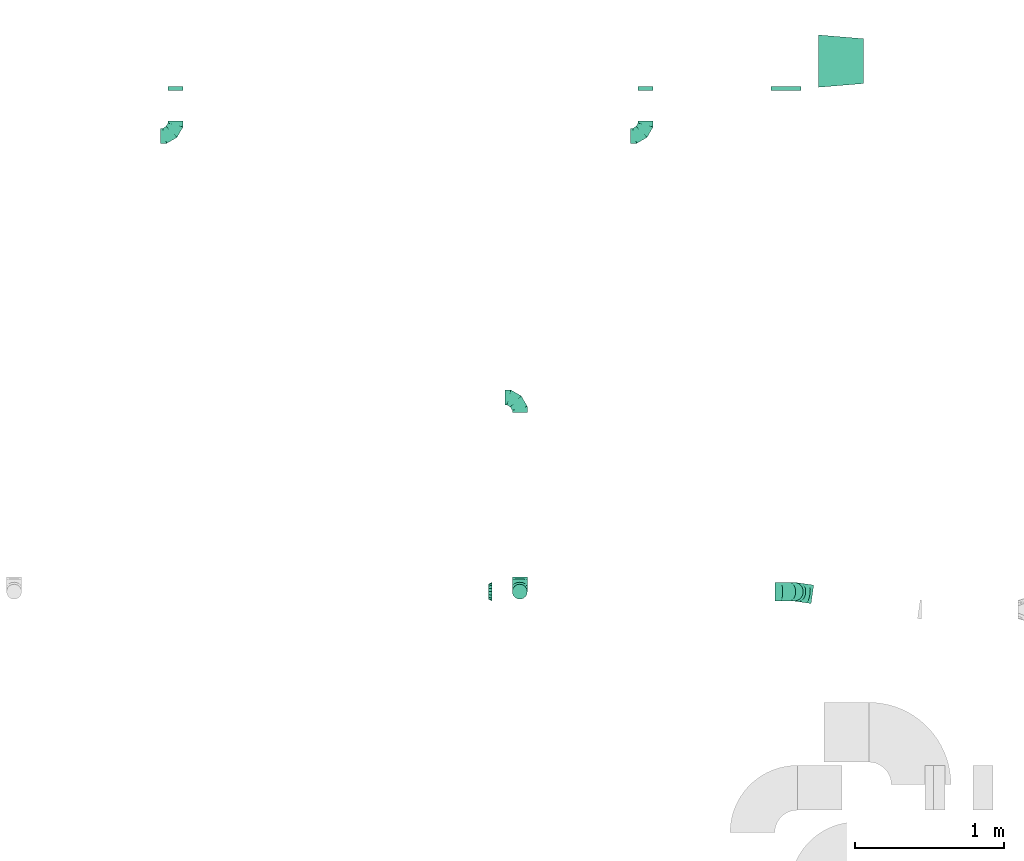
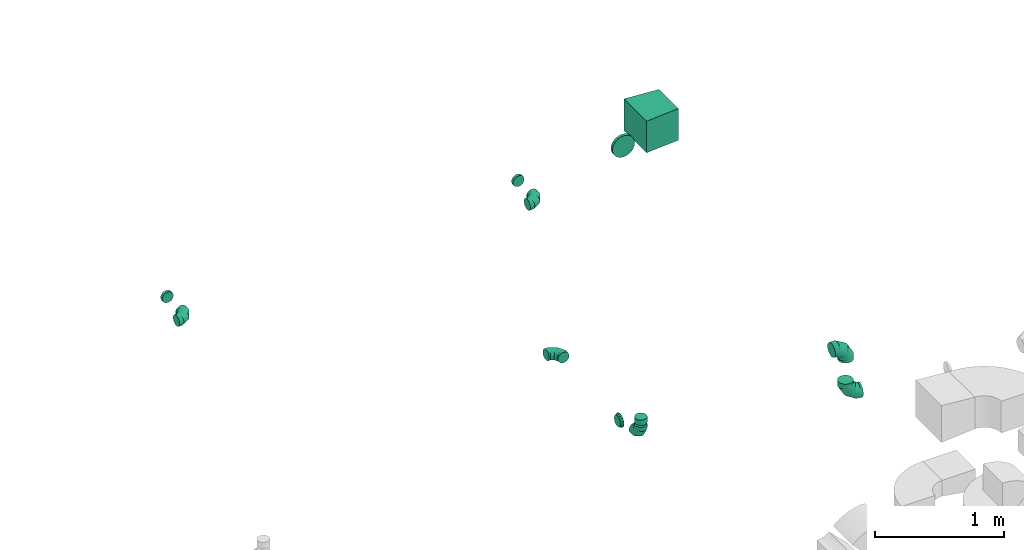
# One storey, part 32 of 44: 12 flow fittings.
"""IFC2X3 building model written with IfcOpenShell, lengths in millimetres."""

from ifc_helpers import new_model, entity, si_unit, converted_unit, derived_unit, direction, frame, origin, place, context, subcontext, project, spatial, polyline, outline, extrude, faceted_brep, source, transform, mapped, material, type_object, type_shapes, element, save


model = new_model("IFC2X3")

# Units and contexts
model_context = context("Model", 3, precision=0.01, world=origin(), true_north=direction((6.12303176911189e-17, 1.0)))
body_context = subcontext(model_context, "Body", "Model", "MODEL_VIEW")
ifc_project = project(units=[si_unit("LENGTHUNIT", "METRE", prefix="MILLI"), si_unit("AREAUNIT", "SQUARE_METRE"), si_unit("VOLUMEUNIT", "CUBIC_METRE"), converted_unit("PLANEANGLEUNIT", "DEGREE", entity("IfcRatioMeasure", 0.0174532925199433), si_unit("PLANEANGLEUNIT", "RADIAN"), dimensions=[0, 0, 0, 0, 0, 0, 0]), si_unit("MASSUNIT", "GRAM", prefix="KILO"), derived_unit("MASSDENSITYUNIT", [(si_unit("MASSUNIT", "GRAM", prefix="KILO"), 1), (si_unit("LENGTHUNIT", "METRE"), -3)]), derived_unit("MOMENTOFINERTIAUNIT", [(si_unit("LENGTHUNIT", "METRE"), 4)]), si_unit("TIMEUNIT", "SECOND"), si_unit("FREQUENCYUNIT", "HERTZ"), si_unit("THERMODYNAMICTEMPERATUREUNIT", "DEGREE_CELSIUS"), derived_unit("THERMALTRANSMITTANCEUNIT", [(si_unit("MASSUNIT", "GRAM", prefix="KILO"), 1), (si_unit("THERMODYNAMICTEMPERATUREUNIT", "KELVIN"), -1), (si_unit("TIMEUNIT", "SECOND"), -3)]), derived_unit("VOLUMETRICFLOWRATEUNIT", [(si_unit("LENGTHUNIT", "METRE"), 3), (si_unit("TIMEUNIT", "SECOND"), -1)]), derived_unit("MASSFLOWRATEUNIT", [(si_unit("MASSUNIT", "GRAM", prefix="KILO"), 1), (si_unit("TIMEUNIT", "SECOND"), -1)]), derived_unit("ROTATIONALFREQUENCYUNIT", [(si_unit("TIMEUNIT", "SECOND"), -1)]), si_unit("ELECTRICCURRENTUNIT", "AMPERE"), si_unit("ELECTRICVOLTAGEUNIT", "VOLT"), si_unit("POWERUNIT", "WATT"), si_unit("FORCEUNIT", "NEWTON", prefix="KILO"), si_unit("ILLUMINANCEUNIT", "LUX"), si_unit("LUMINOUSFLUXUNIT", "LUMEN"), si_unit("LUMINOUSINTENSITYUNIT", "CANDELA"), derived_unit("USERDEFINED", [(si_unit("MASSUNIT", "GRAM", prefix="KILO"), -1), (si_unit("LENGTHUNIT", "METRE"), -2), (si_unit("TIMEUNIT", "SECOND"), 3), (si_unit("LUMINOUSFLUXUNIT", "LUMEN"), 1)]), derived_unit("LINEARVELOCITYUNIT", [(si_unit("LENGTHUNIT", "METRE"), 1), (si_unit("TIMEUNIT", "SECOND"), -1)]), si_unit("PRESSUREUNIT", "PASCAL"), derived_unit("USERDEFINED", [(si_unit("LENGTHUNIT", "METRE"), -2), (si_unit("MASSUNIT", "GRAM", prefix="KILO"), 1), (si_unit("TIMEUNIT", "SECOND"), -2)]), derived_unit("LINEARFORCEUNIT", [(si_unit("MASSUNIT", "GRAM", prefix="KILO"), 1), (si_unit("LENGTHUNIT", "METRE"), 1), (si_unit("TIMEUNIT", "SECOND"), -2), (si_unit("LENGTHUNIT", "METRE"), -1)]), derived_unit("PLANARFORCEUNIT", [(si_unit("MASSUNIT", "GRAM", prefix="KILO"), 1), (si_unit("LENGTHUNIT", "METRE"), 1), (si_unit("TIMEUNIT", "SECOND"), -2), (si_unit("LENGTHUNIT", "METRE"), -2)])], contexts=[model_context])

# Site, building, storey
site_placement = place(None, origin())
site = spatial("IfcSite", under=ifc_project, at=site_placement, CompositionType="ELEMENT")
building_placement = place(site_placement, origin())
building = spatial("IfcBuilding", under=site, at=building_placement, CompositionType="ELEMENT")
storey_placement = place(building_placement, frame((0.0, 0.0, 15900.0)))
storey = spatial("IfcBuildingStorey", under=building, at=storey_placement, CompositionType="ELEMENT", Elevation=15900.0)

# Flow fittings
ifc_material = material()
duct_fitting_type_1 = type_object("IfcDuctFittingType", PredefinedType="NOTDEFINED", material=ifc_material)
shared_shape_1 = source(origin(), body_context, "Body", "SweptSolid", [
    extrude(outline(polyline([(-164.01, -161.94), (137.03, -161.94), (161.94, 137.03), (-134.95, 186.85), (-164.01, -161.94)])), frame((150.0, 0.0, -150.0), z_axis=(0.0, 0.0, 1.0), x_axis=(0.99654575824488, 0.0830454798537382, 0.0)), (0.0, 0.0, 1.0), 300.0),
])
type_shapes(duct_fitting_type_1, [shared_shape_1])
flow_fitting_1_placement = place(storey_placement, frame((37762.78, 19800.32, 3270.0)))
element("IfcFlowFitting", 1, at=flow_fitting_1_placement, inside=storey, type_object=duct_fitting_type_1, material=ifc_material, context=body_context, shape_type="MappedRepresentation", body=[
    mapped(shared_shape_1, transform((0.0, 0.0, 0.0), scale=1.0)),
])
duct_fitting_type_2 = type_object("IfcDuctFittingType", PredefinedType="NOTDEFINED", material=ifc_material)
shared_shape_2 = source(origin(), body_context, "Body", "Brep", [
    faceted_brep([(-100.0, 0.0, -50.0), (-100.0, -12.94, -48.3), (-100.0, -25.0, -43.3), (-100.0, -35.36, -35.36), (-100.0, -43.3, -25.0), (-100.0, -48.3, -12.94), (-100.0, -50.0, 0.0), (-100.0, -48.3, 12.94), (-100.0, -43.3, 25.0), (-100.0, -35.36, 35.36), (-100.0, -25.0, 43.3), (-100.0, -12.94, 48.3), (-100.0, 0.0, 50.0), (-100.0, 12.94, 48.3), (-100.0, 25.0, 43.3), (-100.0, 35.36, 35.36), (-100.0, 43.3, 25.0), (-100.0, 48.3, 12.94), (-100.0, 50.0, 0.0), (-100.0, 48.3, -12.94), (-100.0, 43.3, -25.0), (-100.0, 35.36, -35.36), (-100.0, 25.0, -43.3), (-100.0, 12.94, -48.3), (-76.67, 12.94, 48.3), (-79.9, 25.0, 43.3), (-73.21, 0.0, 50.0), (-82.68, 35.36, 35.36), (-86.15, 48.3, 12.94), (-86.6, 50.0, 0.0), (-84.81, 43.3, 25.0), (-84.81, 43.3, -25.0), (-82.68, 35.36, -35.36), (-86.15, 48.3, -12.94), (-76.67, 12.94, -48.3), (-73.21, 0.0, -50.0), (-79.9, 25.0, -43.3), (-69.74, -12.94, -48.3), (-66.51, -25.0, -43.3), (-63.73, -35.36, -35.36), (-61.6, -43.3, -25.0), (-60.26, -48.3, -12.94), (-59.81, -50.0, 0.0), (-60.26, -48.3, 12.94), (-61.6, -43.3, 25.0), (-63.73, -35.36, 35.36), (-66.51, -25.0, 43.3), (-69.74, -12.94, 48.3), (-36.27, 36.27, 48.3), (-45.1, 45.1, 43.3), (-26.79, 26.79, 50.0), (-52.68, 52.68, 35.36), (-58.49, 58.49, 25.0), (-62.15, 62.15, 12.94), (-63.4, 63.4, 0.0), (-62.15, 62.15, -12.94), (-58.49, 58.49, -25.0), (-52.68, 52.68, -35.36), (-36.27, 36.27, -48.3), (-26.79, 26.79, -50.0), (-45.1, 45.1, -43.3), (-17.32, 17.32, -48.3), (-8.49, 8.49, -43.3), (-0.91, 0.91, -35.36), (4.9, -4.9, -25.0), (8.56, -8.56, -12.94), (9.81, -9.81, 0.0), (8.56, -8.56, 12.94), (4.9, -4.9, 25.0), (-0.91, 0.91, 35.36), (-8.49, 8.49, 43.3), (-17.32, 17.32, 48.3), (-12.94, 76.67, 48.3), (-25.0, 79.9, 43.3), (0.0, 73.21, 50.0), (-35.36, 82.68, 35.36), (-43.3, 84.81, 25.0), (-48.3, 86.15, 12.94), (-50.0, 86.6, 0.0), (-48.3, 86.15, -12.94), (-43.3, 84.81, -25.0), (-35.36, 82.68, -35.36), (-12.94, 76.67, -48.3), (0.0, 73.21, -50.0), (-25.0, 79.9, -43.3), (12.94, 69.74, -48.3), (25.0, 66.51, -43.3), (35.36, 63.73, -35.36), (43.3, 61.6, -25.0), (48.3, 60.26, -12.94), (50.0, 59.81, 0.0), (48.3, 60.26, 12.94), (43.3, 61.6, 25.0), (35.36, 63.73, 35.36), (25.0, 66.51, 43.3), (12.94, 69.74, 48.3), (-12.94, 100.0, -48.3), (-25.0, 100.0, -43.3), (-35.36, 100.0, -35.36), (-43.3, 100.0, -25.0), (-48.3, 100.0, -12.94), (-50.0, 100.0, 0.0), (-48.3, 100.0, 12.94), (-43.3, 100.0, 25.0), (-35.36, 100.0, 35.36), (-25.0, 100.0, 43.3), (-12.94, 100.0, 48.3), (0.0, 100.0, 50.0), (12.94, 100.0, 48.3), (25.0, 100.0, 43.3), (35.36, 100.0, 35.36), (43.3, 100.0, 25.0), (48.3, 100.0, 12.94), (50.0, 100.0, 0.0), (48.3, 100.0, -12.94), (43.3, 100.0, -25.0), (35.36, 100.0, -35.36), (25.0, 100.0, -43.3), (12.94, 100.0, -48.3), (0.0, 100.0, -50.0)], [[[0, 1, 2, 3, 4, 5, 6, 7, 8, 9, 10, 11, 12, 13, 14, 15, 16, 17, 18, 19, 20, 21, 22, 23]], [[24, 25, 14, 13]], [[26, 24, 13, 12]], [[14, 25, 27, 15]], [[28, 29, 18, 17]], [[30, 28, 17, 16]], [[15, 27, 30, 16]], [[20, 31, 32, 21]], [[33, 31, 20, 19]], [[18, 29, 33, 19]], [[34, 35, 0, 23]], [[36, 34, 23, 22]], [[32, 36, 22, 21]], [[2, 1, 37, 38]], [[3, 2, 38, 39]], [[0, 35, 37, 1]], [[5, 4, 40, 41]], [[6, 5, 41, 42]], [[3, 39, 40, 4]], [[6, 42, 43, 7]], [[7, 43, 44, 8]], [[8, 44, 45, 9]], [[10, 46, 47, 11]], [[11, 47, 26, 12]], [[10, 9, 45, 46]], [[48, 49, 25, 24]], [[50, 48, 24, 26]], [[27, 25, 49, 51]], [[52, 53, 28, 30]], [[51, 52, 30, 27]], [[29, 28, 53, 54]], [[55, 56, 31, 33]], [[54, 55, 33, 29]], [[57, 32, 31, 56]], [[58, 59, 35, 34]], [[60, 58, 34, 36]], [[57, 60, 36, 32]], [[37, 35, 59, 61]], [[38, 37, 61, 62]], [[39, 38, 62, 63]], [[41, 40, 64, 65]], [[42, 41, 65, 66]], [[63, 64, 40, 39]], [[43, 42, 66, 67]], [[44, 43, 67, 68]], [[68, 69, 45, 44]], [[46, 45, 69, 70]], [[47, 46, 70, 71]], [[26, 47, 71, 50]], [[72, 73, 49, 48]], [[74, 72, 48, 50]], [[51, 49, 73, 75]], [[76, 77, 53, 52]], [[75, 76, 52, 51]], [[54, 53, 77, 78]], [[79, 80, 56, 55]], [[78, 79, 55, 54]], [[81, 57, 56, 80]], [[82, 83, 59, 58]], [[84, 82, 58, 60]], [[81, 84, 60, 57]], [[61, 59, 83, 85]], [[62, 61, 85, 86]], [[63, 62, 86, 87]], [[65, 64, 88, 89]], [[66, 65, 89, 90]], [[87, 88, 64, 63]], [[67, 66, 90, 91]], [[68, 67, 91, 92]], [[92, 93, 69, 68]], [[70, 69, 93, 94]], [[71, 70, 94, 95]], [[50, 71, 95, 74]], [[96, 97, 98, 99, 100, 101, 102, 103, 104, 105, 106, 107, 108, 109, 110, 111, 112, 113, 114, 115, 116, 117, 118, 119]], [[72, 74, 107, 106]], [[73, 72, 106, 105]], [[75, 73, 105, 104]], [[77, 76, 103, 102]], [[78, 77, 102, 101]], [[75, 104, 103, 76]], [[78, 101, 100, 79]], [[79, 100, 99, 80]], [[80, 99, 98, 81]], [[96, 119, 83, 82]], [[97, 96, 82, 84]], [[84, 81, 98, 97]], [[83, 119, 118, 85]], [[85, 118, 117, 86]], [[86, 117, 116, 87]], [[88, 115, 114, 89]], [[89, 114, 113, 90]], [[87, 116, 115, 88]], [[91, 90, 113, 112]], [[92, 91, 112, 111]], [[93, 92, 111, 110]], [[95, 94, 109, 108]], [[74, 95, 108, 107]], [[110, 109, 94, 93]]]),
])
type_shapes(duct_fitting_type_2, [shared_shape_2])
for number, where in (
    (2, (36604.95, 19299.7, 3270.0)),
    (3, (33460.05, 19299.86, 3270.0)),
):
    element("IfcFlowFitting", number, at=place(storey_placement, frame(where)), inside=storey, type_object=duct_fitting_type_2, material=ifc_material, context=body_context, shape_type="MappedRepresentation", body=[
        mapped(shared_shape_2, transform((0.0, 0.0, 0.0), scale=1.0)),
    ])
for number, where, z_axis, x_axis in (
    (4, (35763.58, 17550.24, 3200.0), (0.0, 0.0, 1.0), (0.0, 1.0, 0.0)),
    (5, (35763.58, 16250.36, 3200.0), (1.0, 0.0, 0.0), (0.0, 0.0, -1.0)),
):
    element("IfcFlowFitting", number, at=place(storey_placement, frame(where, z_axis=z_axis, x_axis=x_axis)), inside=storey, type_object=duct_fitting_type_2, material=ifc_material, context=body_context, shape_type="MappedRepresentation", body=[
        mapped(shared_shape_2, transform((0.0, 0.0, 0.0), scale=1.0)),
    ])
duct_fitting_type_3 = type_object("IfcDuctFittingType", PredefinedType="NOTDEFINED", material=ifc_material)
shared_shape_3 = source(origin(), body_context, "Body", "Brep", [
    faceted_brep([(-125.0, 0.0, -62.5), (-125.0, -16.18, -60.37), (-125.0, -31.25, -54.13), (-125.0, -44.19, -44.19), (-125.0, -54.13, -31.25), (-125.0, -60.37, -16.18), (-125.0, -62.5, 0.0), (-125.0, -60.37, 16.18), (-125.0, -54.13, 31.25), (-125.0, -44.19, 44.19), (-125.0, -31.25, 54.13), (-125.0, -16.18, 60.37), (-125.0, 0.0, 62.5), (-125.0, 16.18, 60.37), (-125.0, 31.25, 54.13), (-125.0, 44.19, 44.19), (-125.0, 54.13, 31.25), (-125.0, 60.37, 16.18), (-125.0, 62.5, 0.0), (-125.0, 60.37, -16.18), (-125.0, 54.13, -31.25), (-125.0, 44.19, -44.19), (-125.0, 31.25, -54.13), (-125.0, 16.18, -60.37), (-95.84, 16.18, 60.37), (-99.88, 31.25, 54.13), (-91.51, 0.0, 62.5), (-103.35, 44.19, 44.19), (-107.68, 60.37, 16.18), (-108.25, 62.5, 0.0), (-106.01, 54.13, 31.25), (-106.01, 54.13, -31.25), (-103.35, 44.19, -44.19), (-107.68, 60.37, -16.18), (-95.84, 16.18, -60.37), (-91.51, 0.0, -62.5), (-99.88, 31.25, -54.13), (-87.17, -16.18, -60.37), (-83.13, -31.25, -54.13), (-79.66, -44.19, -44.19), (-77.0, -54.13, -31.25), (-75.33, -60.37, -16.18), (-74.76, -62.5, 0.0), (-75.33, -60.37, 16.18), (-77.0, -54.13, 31.25), (-79.66, -44.19, 44.19), (-83.13, -31.25, 54.13), (-87.17, -16.18, 60.37), (-45.34, 45.34, 60.37), (-56.37, 56.37, 54.13), (-33.49, 33.49, 62.5), (-65.85, 65.85, 44.19), (-73.12, 73.12, 31.25), (-77.69, 77.69, 16.18), (-79.25, 79.25, 0.0), (-77.69, 77.69, -16.18), (-73.12, 73.12, -31.25), (-65.85, 65.85, -44.19), (-45.34, 45.34, -60.37), (-33.49, 33.49, -62.5), (-56.37, 56.37, -54.13), (-21.65, 21.65, -60.37), (-10.62, 10.62, -54.13), (-1.14, 1.14, -44.19), (6.13, -6.13, -31.25), (10.7, -10.7, -16.18), (12.26, -12.26, 0.0), (10.7, -10.7, 16.18), (6.13, -6.13, 31.25), (-1.14, 1.14, 44.19), (-10.62, 10.62, 54.13), (-21.65, 21.65, 60.37), (-16.18, 95.84, 60.37), (-31.25, 99.88, 54.13), (0.0, 91.51, 62.5), (-44.19, 103.35, 44.19), (-54.13, 106.01, 31.25), (-60.37, 107.68, 16.18), (-62.5, 108.25, 0.0), (-60.37, 107.68, -16.18), (-54.13, 106.01, -31.25), (-44.19, 103.35, -44.19), (-16.18, 95.84, -60.37), (0.0, 91.51, -62.5), (-31.25, 99.88, -54.13), (16.18, 87.17, -60.37), (31.25, 83.13, -54.13), (44.19, 79.66, -44.19), (54.13, 77.0, -31.25), (60.37, 75.33, -16.18), (62.5, 74.76, 0.0), (60.37, 75.33, 16.18), (54.13, 77.0, 31.25), (44.19, 79.66, 44.19), (31.25, 83.13, 54.13), (16.18, 87.17, 60.37), (-16.18, 125.0, -60.37), (-31.25, 125.0, -54.13), (-44.19, 125.0, -44.19), (-54.13, 125.0, -31.25), (-60.37, 125.0, -16.18), (-62.5, 125.0, 0.0), (-60.37, 125.0, 16.18), (-54.13, 125.0, 31.25), (-44.19, 125.0, 44.19), (-31.25, 125.0, 54.13), (-16.18, 125.0, 60.37), (0.0, 125.0, 62.5), (16.18, 125.0, 60.37), (31.25, 125.0, 54.13), (44.19, 125.0, 44.19), (54.13, 125.0, 31.25), (60.37, 125.0, 16.18), (62.5, 125.0, 0.0), (60.37, 125.0, -16.18), (54.13, 125.0, -31.25), (44.19, 125.0, -44.19), (31.25, 125.0, -54.13), (16.18, 125.0, -60.37), (0.0, 125.0, -62.5)], [[[0, 1, 2, 3, 4, 5, 6, 7, 8, 9, 10, 11, 12, 13, 14, 15, 16, 17, 18, 19, 20, 21, 22, 23]], [[24, 25, 14, 13]], [[26, 24, 13, 12]], [[14, 25, 27, 15]], [[28, 29, 18, 17]], [[30, 28, 17, 16]], [[15, 27, 30, 16]], [[20, 31, 32, 21]], [[33, 31, 20, 19]], [[18, 29, 33, 19]], [[34, 35, 0, 23]], [[36, 34, 23, 22]], [[21, 32, 36, 22]], [[1, 0, 35, 37]], [[2, 1, 37, 38]], [[38, 39, 3, 2]], [[5, 4, 40, 41]], [[6, 5, 41, 42]], [[39, 40, 4, 3]], [[6, 42, 43, 7]], [[7, 43, 44, 8]], [[45, 9, 8, 44]], [[9, 45, 46, 10]], [[10, 46, 47, 11]], [[26, 12, 11, 47]], [[48, 49, 25, 24]], [[50, 48, 24, 26]], [[27, 25, 49, 51]], [[52, 53, 28, 30]], [[51, 52, 30, 27]], [[29, 28, 53, 54]], [[55, 56, 31, 33]], [[54, 55, 33, 29]], [[57, 32, 31, 56]], [[58, 59, 35, 34]], [[60, 58, 34, 36]], [[57, 60, 36, 32]], [[37, 35, 59, 61]], [[38, 37, 61, 62]], [[39, 38, 62, 63]], [[41, 40, 64, 65]], [[42, 41, 65, 66]], [[63, 64, 40, 39]], [[43, 42, 66, 67]], [[44, 43, 67, 68]], [[68, 69, 45, 44]], [[46, 45, 69, 70]], [[47, 46, 70, 71]], [[26, 47, 71, 50]], [[72, 73, 49, 48]], [[74, 72, 48, 50]], [[51, 49, 73, 75]], [[76, 77, 53, 52]], [[75, 76, 52, 51]], [[54, 53, 77, 78]], [[79, 80, 56, 55]], [[78, 79, 55, 54]], [[81, 57, 56, 80]], [[82, 83, 59, 58]], [[84, 82, 58, 60]], [[81, 84, 60, 57]], [[61, 59, 83, 85]], [[62, 61, 85, 86]], [[63, 62, 86, 87]], [[65, 64, 88, 89]], [[66, 65, 89, 90]], [[87, 88, 64, 63]], [[67, 66, 90, 91]], [[68, 67, 91, 92]], [[92, 93, 69, 68]], [[70, 69, 93, 94]], [[71, 70, 94, 95]], [[50, 71, 95, 74]], [[96, 97, 98, 99, 100, 101, 102, 103, 104, 105, 106, 107, 108, 109, 110, 111, 112, 113, 114, 115, 116, 117, 118, 119]], [[72, 74, 107, 106]], [[73, 72, 106, 105]], [[75, 73, 105, 104]], [[77, 76, 103, 102]], [[78, 77, 102, 101]], [[75, 104, 103, 76]], [[78, 101, 100, 79]], [[79, 100, 99, 80]], [[80, 99, 98, 81]], [[96, 119, 83, 82]], [[97, 96, 82, 84]], [[84, 81, 98, 97]], [[83, 119, 118, 85]], [[85, 118, 117, 86]], [[116, 87, 86, 117]], [[88, 115, 114, 89]], [[89, 114, 113, 90]], [[115, 88, 87, 116]], [[91, 90, 113, 112]], [[92, 91, 112, 111]], [[111, 110, 93, 92]], [[95, 94, 109, 108]], [[74, 95, 108, 107]], [[110, 109, 94, 93]]]),
])
type_shapes(duct_fitting_type_3, [shared_shape_3])
for number, where, z_axis, x_axis in (
    (6, (37597.66, 16250.36, 3400.0), (0.0, 1.0, 0.0), (1.0, 0.0, 0.0)),
    (7, (37597.66, 16250.36, 2950.0), (-0.13933376387891, -0.990245475749996, 0.0), (0.0, 0.0, -1.0)),
):
    element("IfcFlowFitting", number, at=place(storey_placement, frame(where, z_axis=z_axis, x_axis=x_axis)), inside=storey, type_object=duct_fitting_type_3, material=ifc_material, context=body_context, shape_type="MappedRepresentation", body=[
        mapped(shared_shape_3, transform((0.0, 0.0, 0.0), scale=1.0)),
    ])
duct_fitting_type_4 = type_object("IfcDuctFittingType", PredefinedType="NOTDEFINED", material=ifc_material)
shared_shape_4 = source(origin(), body_context, "Body", "Brep", [
    faceted_brep([(20.0, 25.88, -96.59), (20.0, 50.0, -86.6), (20.0, 70.71, -70.71), (20.0, 86.6, -50.0), (20.0, 96.59, -25.88), (20.0, 100.0, 0.0), (20.0, 96.59, 25.88), (20.0, 86.6, 50.0), (20.0, 70.71, 70.71), (20.0, 50.0, 86.6), (20.0, 25.88, 96.59), (20.0, 0.0, 100.0), (20.0, -25.88, 96.59), (20.0, -50.0, 86.6), (20.0, -70.71, 70.71), (20.0, -86.6, 50.0), (20.0, -96.59, 25.88), (20.0, -100.0, 0.0), (20.0, -96.59, -25.88), (20.0, -86.6, -50.0), (20.0, -70.71, -70.71), (20.0, -50.0, -86.6), (20.0, -25.88, -96.59), (20.0, 0.0, -100.0), (0.0, 0.0, 100.0), (0.0, 25.88, 96.59), (-6.1, 25.88, 96.59), (-6.1, 0.0, 100.0), (0.0, 50.0, 86.6), (-6.1, 50.0, 86.6), (0.0, 70.71, 70.71), (-6.1, 70.71, 70.71), (0.0, 86.6, 50.0), (0.0, 96.59, 25.88), (-6.1, 96.59, 25.88), (-6.1, 86.6, 50.0), (0.0, 100.0, 0.0), (-6.1, 100.0, 0.0), (0.0, 96.59, -25.88), (-6.1, 96.59, -25.88), (0.0, 86.6, -50.0), (-6.1, 86.6, -50.0), (0.0, 70.71, -70.71), (-6.1, 70.71, -70.71), (0.0, 50.0, -86.6), (0.0, 25.88, -96.59), (-6.1, 25.88, -96.59), (-6.1, 50.0, -86.6), (0.0, 0.0, -100.0), (-6.1, 0.0, -100.0), (0.0, -25.88, -96.59), (-6.1, -25.88, -96.59), (0.0, -50.0, -86.6), (-6.1, -50.0, -86.6), (0.0, -70.71, -70.71), (-6.1, -70.71, -70.71), (0.0, -86.6, -50.0), (0.0, -96.59, -25.88), (-6.1, -96.59, -25.88), (-6.1, -86.6, -50.0), (0.0, -100.0, 0.0), (-6.1, -100.0, 0.0), (0.0, -96.59, 25.88), (-6.1, -96.59, 25.88), (0.0, -86.6, 50.0), (-6.1, -86.6, 50.0), (0.0, -70.71, 70.71), (-6.1, -70.71, 70.71), (0.0, -50.0, 86.6), (0.0, -25.88, 96.59), (-6.1, -25.88, 96.59), (-6.1, -50.0, 86.6)], [[[0, 1, 2, 3, 4, 5, 6, 7, 8, 9, 10, 11, 12, 13, 14, 15, 16, 17, 18, 19, 20, 21, 22, 23]], [[24, 11, 10, 25, 26, 27]], [[25, 10, 9, 28, 29, 26]], [[28, 9, 8, 30, 31, 29]], [[32, 7, 6, 33, 34, 35]], [[33, 6, 5, 36, 37, 34]], [[30, 8, 7, 32, 35, 31]], [[36, 5, 4, 38, 39, 37]], [[38, 4, 3, 40, 41, 39]], [[40, 3, 2, 42, 43, 41]], [[44, 1, 0, 45, 46, 47]], [[45, 0, 23, 48, 49, 46]], [[42, 2, 1, 44, 47, 43]], [[48, 23, 22, 50, 51, 49]], [[50, 22, 21, 52, 53, 51]], [[52, 21, 20, 54, 55, 53]], [[56, 19, 18, 57, 58, 59]], [[57, 18, 17, 60, 61, 58]], [[54, 20, 19, 56, 59, 55]], [[60, 17, 16, 62, 63, 61]], [[62, 16, 15, 64, 65, 63]], [[64, 15, 14, 66, 67, 65]], [[68, 13, 12, 69, 70, 71]], [[69, 12, 11, 24, 27, 70]], [[66, 14, 13, 68, 71, 67]], [[49, 51, 53, 55, 59, 58, 61, 63, 65, 67, 71, 70, 27, 26, 29, 31, 35, 34, 37, 39, 41, 43, 47, 46]]]),
])
type_shapes(duct_fitting_type_4, [shared_shape_4])
flow_fitting_2_placement = place(storey_placement, frame((37545.76, 19625.32, 3270.0), z_axis=(0.0, 0.0, -1.0), x_axis=(0.0, -1.0, 0.0)))
element("IfcFlowFitting", 8, at=flow_fitting_2_placement, inside=storey, type_object=duct_fitting_type_4, material=ifc_material, context=body_context, shape_type="MappedRepresentation", body=[
    mapped(shared_shape_4, transform((0.0, 0.0, 0.0), scale=1.0)),
])
duct_fitting_type_5 = type_object("IfcDuctFittingType", PredefinedType="NOTDEFINED", material=ifc_material)
shared_shape_5 = source(origin(), body_context, "Body", "Brep", [
    faceted_brep([(25.0, 0.0, -62.5), (25.0, 12.45, -60.02), (25.0, 23.92, -57.74), (25.0, 34.06, -50.97), (25.0, 44.19, -44.19), (25.0, 50.97, -34.06), (25.0, 57.74, -23.92), (25.0, 60.02, -12.45), (25.0, 62.5, 0.0), (25.0, 60.02, 12.45), (25.0, 57.74, 23.92), (25.0, 50.97, 34.06), (25.0, 44.19, 44.19), (25.0, 34.06, 50.97), (25.0, 23.92, 57.74), (25.0, 12.45, 60.02), (25.0, 0.0, 62.5), (25.0, -12.45, 60.02), (25.0, -23.92, 57.74), (25.0, -34.06, 50.97), (25.0, -44.19, 44.19), (25.0, -50.97, 34.06), (25.0, -57.74, 23.92), (25.0, -60.02, 12.45), (25.0, -62.5, 0.0), (25.0, -60.02, -12.45), (25.0, -57.74, -23.92), (25.0, -50.97, -34.06), (25.0, -44.19, -44.19), (25.0, -34.06, -50.97), (25.0, -23.92, -57.74), (25.0, -12.45, -60.02), (0.0, -19.13, -46.19), (0.0, -27.24, -40.77), (0.0, -35.36, -35.36), (0.0, -40.77, -27.24), (0.0, -46.19, -19.13), (0.0, -48.1, -9.57), (0.0, -50.0, 0.0), (0.0, -48.1, 9.57), (0.0, -46.19, 19.13), (0.0, -40.77, 27.24), (0.0, -35.36, 35.36), (0.0, -27.24, 40.77), (0.0, -19.13, 46.19), (0.0, -9.57, 48.1), (0.0, 0.0, 50.0), (0.0, 9.57, 48.1), (0.0, 19.13, 46.19), (0.0, 27.24, 40.77), (0.0, 35.36, 35.36), (0.0, 40.77, 27.24), (0.0, 46.19, 19.13), (0.0, 48.1, 9.57), (0.0, 50.0, 0.0), (0.0, 48.1, -9.57), (0.0, 46.19, -19.13), (0.0, 40.77, -27.24), (0.0, 35.36, -35.36), (0.0, 27.24, -40.77), (0.0, 19.13, -46.19), (0.0, 9.57, -48.1), (0.0, 0.0, -50.0), (0.0, -9.57, -48.1)], [[[0, 1, 2, 3, 4, 5, 6, 7, 8, 9, 10, 11, 12, 13, 14, 15, 16, 17, 18, 19, 20, 21, 22, 23, 24, 25, 26, 27, 28, 29, 30, 31]], [[32, 33, 34, 35, 36, 37, 38, 39, 40, 41, 42, 43, 44, 45, 46, 47, 48, 49, 50, 51, 52, 53, 54, 55, 56, 57, 58, 59, 60, 61, 62, 63]], [[52, 10, 9, 8, 54, 53]], [[51, 50, 12, 11, 10, 52]], [[47, 46, 16, 15, 14, 48]], [[49, 48, 14, 13, 12, 50]], [[44, 18, 17, 16, 46, 45]], [[43, 42, 20, 19, 18, 44]], [[39, 38, 24, 23, 22, 40]], [[41, 40, 22, 21, 20, 42]], [[36, 26, 25, 24, 38, 37]], [[35, 34, 28, 27, 26, 36]], [[63, 62, 0, 31, 30, 32]], [[33, 32, 30, 29, 28, 34]], [[60, 2, 1, 0, 62, 61]], [[59, 58, 4, 3, 2, 60]], [[55, 54, 8, 7, 6, 56]], [[57, 56, 6, 5, 4, 58]]]),
])
type_shapes(duct_fitting_type_5, [shared_shape_5])
flow_fitting_3_placement = place(storey_placement, frame((35552.66, 16250.36, 3400.0)))
element("IfcFlowFitting", 9, at=flow_fitting_3_placement, inside=storey, type_object=duct_fitting_type_5, material=ifc_material, context=body_context, shape_type="MappedRepresentation", body=[
    mapped(shared_shape_5, transform((0.0, 0.0, 0.0), scale=1.0)),
])
duct_fitting_type_6 = type_object("IfcDuctFittingType", PredefinedType="NOTDEFINED", material=ifc_material)
shared_shape_6 = source(origin(), body_context, "Body", "Brep", [
    faceted_brep([(20.0, 12.94, -48.3), (20.0, 25.0, -43.3), (20.0, 35.36, -35.36), (20.0, 43.3, -25.0), (20.0, 48.3, -12.94), (20.0, 50.0, 0.0), (20.0, 48.3, 12.94), (20.0, 43.3, 25.0), (20.0, 35.36, 35.36), (20.0, 25.0, 43.3), (20.0, 12.94, 48.3), (20.0, 0.0, 50.0), (20.0, -12.94, 48.3), (20.0, -25.0, 43.3), (20.0, -35.36, 35.36), (20.0, -43.3, 25.0), (20.0, -48.3, 12.94), (20.0, -50.0, 0.0), (20.0, -48.3, -12.94), (20.0, -43.3, -25.0), (20.0, -35.36, -35.36), (20.0, -25.0, -43.3), (20.0, -12.94, -48.3), (20.0, 0.0, -50.0), (0.0, 0.0, 50.0), (0.0, 12.94, 48.3), (-6.1, 12.94, 48.3), (-6.1, 0.0, 50.0), (0.0, 25.0, 43.3), (-6.1, 25.0, 43.3), (0.0, 35.36, 35.36), (-6.1, 35.36, 35.36), (0.0, 43.3, 25.0), (0.0, 48.3, 12.94), (-6.1, 48.3, 12.94), (-6.1, 43.3, 25.0), (0.0, 50.0, 0.0), (-6.1, 50.0, 0.0), (0.0, 48.3, -12.94), (-6.1, 48.3, -12.94), (0.0, 43.3, -25.0), (-6.1, 43.3, -25.0), (0.0, 35.36, -35.36), (-6.1, 35.36, -35.36), (0.0, 25.0, -43.3), (0.0, 12.94, -48.3), (-6.1, 12.94, -48.3), (-6.1, 25.0, -43.3), (0.0, 0.0, -50.0), (-6.1, 0.0, -50.0), (0.0, -12.94, -48.3), (-6.1, -12.94, -48.3), (0.0, -25.0, -43.3), (-6.1, -25.0, -43.3), (0.0, -35.36, -35.36), (-6.1, -35.36, -35.36), (0.0, -43.3, -25.0), (0.0, -48.3, -12.94), (-6.1, -48.3, -12.94), (-6.1, -43.3, -25.0), (0.0, -50.0, 0.0), (-6.1, -50.0, 0.0), (0.0, -48.3, 12.94), (-6.1, -48.3, 12.94), (0.0, -43.3, 25.0), (-6.1, -43.3, 25.0), (0.0, -35.36, 35.36), (-6.1, -35.36, 35.36), (0.0, -25.0, 43.3), (0.0, -12.94, 48.3), (-6.1, -12.94, 48.3), (-6.1, -25.0, 43.3)], [[[0, 1, 2, 3, 4, 5, 6, 7, 8, 9, 10, 11, 12, 13, 14, 15, 16, 17, 18, 19, 20, 21, 22, 23]], [[24, 11, 10, 25, 26, 27]], [[25, 10, 9, 28, 29, 26]], [[28, 9, 8, 30, 31, 29]], [[32, 7, 6, 33, 34, 35]], [[33, 6, 5, 36, 37, 34]], [[30, 8, 7, 32, 35, 31]], [[36, 5, 4, 38, 39, 37]], [[38, 4, 3, 40, 41, 39]], [[40, 3, 2, 42, 43, 41]], [[44, 1, 0, 45, 46, 47]], [[45, 0, 23, 48, 49, 46]], [[42, 2, 1, 44, 47, 43]], [[48, 23, 22, 50, 51, 49]], [[50, 22, 21, 52, 53, 51]], [[52, 21, 20, 54, 55, 53]], [[56, 19, 18, 57, 58, 59]], [[57, 18, 17, 60, 61, 58]], [[54, 20, 19, 56, 59, 55]], [[60, 17, 16, 62, 63, 61]], [[62, 16, 15, 64, 65, 63]], [[64, 15, 14, 66, 67, 65]], [[68, 13, 12, 69, 70, 71]], [[69, 12, 11, 24, 27, 70]], [[66, 14, 13, 68, 71, 67]], [[49, 51, 53, 55, 59, 58, 61, 63, 65, 67, 71, 70, 27, 26, 29, 31, 35, 34, 37, 39, 41, 43, 47, 46]]]),
])
type_shapes(duct_fitting_type_6, [shared_shape_6])
for number, where, z_axis, x_axis in (
    (10, (36604.95, 19625.32, 3270.0), (0.0, 0.0, -1.0), (0.0, -1.0, 0.0)),
    (11, (33460.05, 19625.32, 3270.0), (0.0, 0.0, -1.0), (0.0, -1.0, 0.0)),
):
    element("IfcFlowFitting", number, at=place(storey_placement, frame(where, z_axis=z_axis, x_axis=x_axis)), inside=storey, type_object=duct_fitting_type_6, material=ifc_material, context=body_context, shape_type="MappedRepresentation", body=[
        mapped(shared_shape_6, transform((0.0, 0.0, 0.0), scale=1.0)),
    ])
duct_fitting_type_7 = type_object("IfcDuctFittingType", PredefinedType="NOTDEFINED", material=ifc_material)
shared_shape_7 = source(origin(), body_context, "Body", "Brep", [
    faceted_brep([(20.0, 0.0, -50.0), (20.0, 12.94, -48.3), (20.0, 25.0, -43.3), (20.0, 35.36, -35.36), (20.0, 43.3, -25.0), (20.0, 48.3, -12.94), (20.0, 50.0, 0.0), (20.0, 48.3, 12.94), (20.0, 43.3, 25.0), (20.0, 35.36, 35.36), (20.0, 25.0, 43.3), (20.0, 12.94, 48.3), (20.0, 0.0, 50.0), (20.0, -12.94, 48.3), (20.0, -25.0, 43.3), (20.0, -35.36, 35.36), (20.0, -43.3, 25.0), (20.0, -48.3, 12.94), (20.0, -50.0, 0.0), (20.0, -48.3, -12.94), (20.0, -43.3, -25.0), (20.0, -35.36, -35.36), (20.0, -25.0, -43.3), (20.0, -12.94, -48.3), (0.0, 0.0, 50.0), (-31.1, 0.0, 50.0), (-31.1, -12.94, 48.3), (0.0, -12.94, 48.3), (-31.1, -25.0, 43.3), (0.0, -25.0, 43.3), (0.0, -35.36, 35.36), (-31.1, -35.36, 35.36), (0.0, -43.3, 25.0), (-31.1, -43.3, 25.0), (-31.1, -48.3, 12.94), (0.0, -48.3, 12.94), (-31.1, -50.0, 0.0), (0.0, -50.0, 0.0), (-31.1, -48.3, -12.94), (0.0, -48.3, -12.94), (-31.1, -43.3, -25.0), (0.0, -43.3, -25.0), (0.0, -35.36, -35.36), (-31.1, -35.36, -35.36), (0.0, -25.0, -43.3), (-31.1, -25.0, -43.3), (-31.1, -12.94, -48.3), (0.0, -12.94, -48.3), (-31.1, 0.0, -50.0), (0.0, 0.0, -50.0), (-31.1, 12.94, -48.3), (0.0, 12.94, -48.3), (-31.1, 25.0, -43.3), (0.0, 25.0, -43.3), (0.0, 35.36, -35.36), (-31.1, 35.36, -35.36), (0.0, 43.3, -25.0), (-31.1, 43.3, -25.0), (-31.1, 48.3, -12.94), (0.0, 48.3, -12.94), (-31.1, 50.0, 0.0), (0.0, 50.0, 0.0), (-31.1, 48.3, 12.94), (0.0, 48.3, 12.94), (-31.1, 43.3, 25.0), (0.0, 43.3, 25.0), (0.0, 35.36, 35.36), (-31.1, 35.36, 35.36), (0.0, 25.0, 43.3), (-31.1, 25.0, 43.3), (-31.1, 12.94, 48.3), (0.0, 12.94, 48.3)], [[[0, 1, 2, 3, 4, 5, 6, 7, 8, 9, 10, 11, 12, 13, 14, 15, 16, 17, 18, 19, 20, 21, 22, 23]], [[13, 12, 24, 25, 26, 27]], [[14, 13, 27, 26, 28, 29]], [[30, 15, 14, 29, 28, 31]], [[17, 16, 32, 33, 34, 35]], [[18, 17, 35, 34, 36, 37]], [[32, 16, 15, 30, 31, 33]], [[19, 18, 37, 36, 38, 39]], [[20, 19, 39, 38, 40, 41]], [[42, 21, 20, 41, 40, 43]], [[23, 22, 44, 45, 46, 47]], [[0, 23, 47, 46, 48, 49]], [[44, 22, 21, 42, 43, 45]], [[1, 0, 49, 48, 50, 51]], [[2, 1, 51, 50, 52, 53]], [[54, 3, 2, 53, 52, 55]], [[5, 4, 56, 57, 58, 59]], [[6, 5, 59, 58, 60, 61]], [[56, 4, 3, 54, 55, 57]], [[7, 6, 61, 60, 62, 63]], [[8, 7, 63, 62, 64, 65]], [[66, 9, 8, 65, 64, 67]], [[11, 10, 68, 69, 70, 71]], [[12, 11, 71, 70, 25, 24]], [[68, 10, 9, 66, 67, 69]], [[46, 45, 43, 40, 38, 36, 34, 33, 31, 28, 26, 25, 70, 69, 67, 64, 62, 60, 58, 57, 55, 52, 50, 48]]]),
])
type_shapes(duct_fitting_type_7, [shared_shape_7])
flow_fitting_4_placement = place(storey_placement, frame((35763.58, 16250.36, 3337.5), z_axis=(0.0, 1.0, 0.0), x_axis=(0.0, 0.0, -1.0)))
element("IfcFlowFitting", 12, at=flow_fitting_4_placement, inside=storey, type_object=duct_fitting_type_7, material=ifc_material, context=body_context, shape_type="MappedRepresentation", body=[
    mapped(shared_shape_7, transform((0.0, 0.0, 0.0), scale=1.0)),
])

save(model, "model.ifc")
